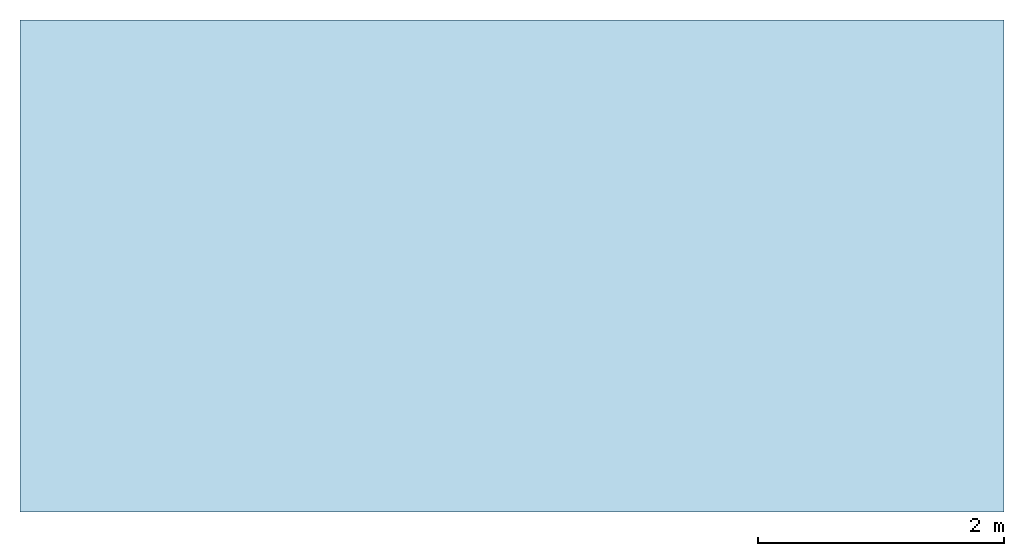
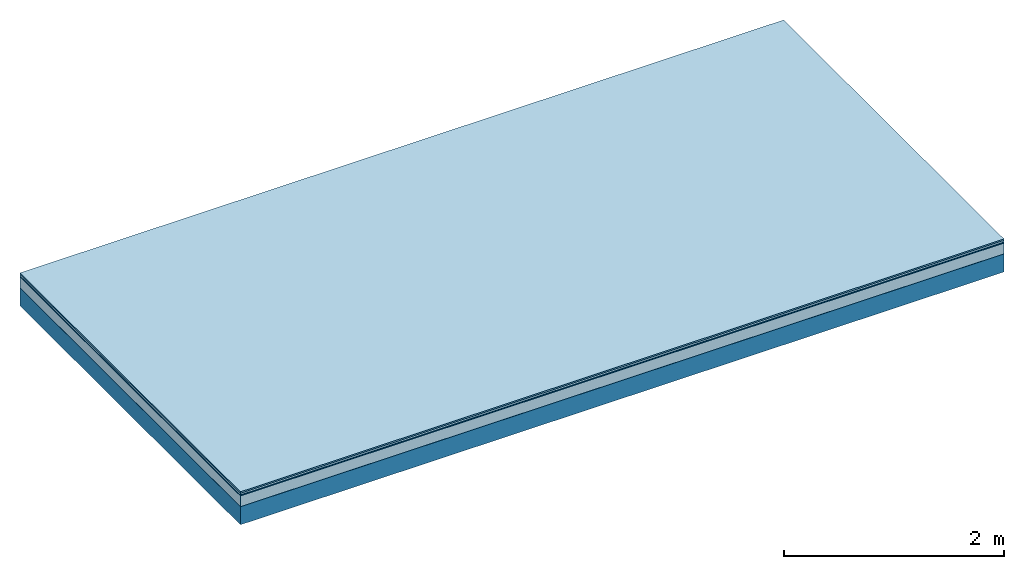
# One storey: 5 plates, 1 member, 1 element without a shape of its own.
"""IFC4 building model written with IfcOpenShell, lengths in metres."""

from ifc_helpers import new_model, si_unit, derived_unit, direction, frame, frame_2d, origin, origin_with_axes, place, context, project, spatial, rectangle, extrude, material, layer, layer_set, type_object, element, aggregate, save


model = new_model("IFC4")

# Units and contexts
plan_context = context("Plan", 3, precision=1e-05, world=origin(), true_north=direction((0.0, 1.0)))
model_context = context("Model", 3, precision=1e-05, world=origin(), true_north=direction((0.0, 1.0)))
ifc_project = project(units=[si_unit("LENGTHUNIT", "METRE"), derived_unit("SOUNDPRESSUREUNIT", [(si_unit("PRESSUREUNIT", "PASCAL", prefix="MICRO"), 0)]), si_unit("ENERGYUNIT", "JOULE", prefix="MEGA"), si_unit("MASSUNIT", "GRAM", prefix="KILO"), derived_unit("THERMALTRANSMITTANCEUNIT", [(si_unit("POWERUNIT", "WATT"), 1), (si_unit("AREAUNIT", "SQUARE_METRE"), -1), (si_unit("THERMODYNAMICTEMPERATUREUNIT", "KELVIN"), -1)]), derived_unit("AREADENSITYUNIT", [(si_unit("MASSUNIT", "GRAM", prefix="KILO"), 1), (si_unit("AREAUNIT", "SQUARE_METRE"), -1)]), derived_unit("USERDEFINED", [(si_unit("ENERGYUNIT", "JOULE", prefix="MEGA"), 1), (si_unit("AREAUNIT", "SQUARE_METRE"), -1)])], contexts=[plan_context, model_context])

# Site, building, storey
site = spatial("IfcSite", under=ifc_project)
building_placement = place(None, origin())
building = spatial("IfcBuilding", under=site, at=building_placement)
storey_placement = place(building_placement, origin())
storey = spatial("IfcBuildingStorey", under=building, at=storey_placement)

# Slab, member, plates
ifc_material_1 = material(Category="11.013")
ifc_layer_1 = layer(ifc_material_1, 0.015, Name="Flooring")
ifc_material_2 = material(Category="03.007")
ifc_layer_2 = layer(ifc_material_2, 0.02, Name="On-material")
ifc_material_3 = material(Name="Wood fiber generic product", Category="10.009")
ifc_layer_3 = layer(ifc_material_3, 0.01, Name="Impact sound insulation")
ifc_material_4 = material(Category="03.011")
ifc_layer_4 = layer(ifc_material_4, 0.12, Name="on Supporting structure")
ifc_material_5 = material(Name="protection", Category="09.007")
ifc_layer_5 = layer(ifc_material_5, 0.0005, Name="Sub-floor")
ifc_material_6 = material(Name="no composite action")
ifc_layer_6 = layer(ifc_material_6, 0.0, Name="Bond")
ifc_layer_7 = layer(None, 0.2, Name="Supporting structure")
ifc_layer_set = layer_set([ifc_layer_1, ifc_layer_2, ifc_layer_3, ifc_layer_4, ifc_layer_5, ifc_layer_6, ifc_layer_7])
slab_type = type_object("IfcSlabType", Name="A2055", PredefinedType="NOTDEFINED", material=ifc_layer_set)
slab_placement = place(None, frame((0.0, 0.0, 0.0), z_axis=(0.0, 0.0, -1.0), x_axis=(1.0, 0.0, 0.0)))
slab = element("IfcSlab", 1, at=slab_placement, inside=storey, type_object=slab_type, material=ifc_layer_set, Name="Slab #1")
ifc_material_7 = material(Name="Solid timber panel")
member_placement = place(slab_placement, origin())
member = element("IfcMember", 2, at=member_placement, material=ifc_material_7, Name="Supporting structure", context=plan_context, shape_type="SweptSolid", body=[
    extrude(rectangle(XDim=1.0, YDim=0.2, at=frame_2d((0.5, 0.1), x_axis=(1.0, 0.0))), frame((0.0, 4.0, 0.1655), z_axis=(0.0, -1.0, 0.0), x_axis=(1.0, 0.0, 0.0)), (0.0, 0.0, 1.0), 4.0),
    extrude(rectangle(XDim=1.0, YDim=0.2, at=frame_2d((0.5, 0.1), x_axis=(1.0, 0.0))), frame((1.0, 4.0, 0.1655), z_axis=(0.0, -1.0, 0.0), x_axis=(1.0, 0.0, 0.0)), (0.0, 0.0, 1.0), 4.0),
    extrude(rectangle(XDim=1.0, YDim=0.2, at=frame_2d((0.5, 0.1), x_axis=(1.0, 0.0))), frame((2.0, 4.0, 0.1655), z_axis=(0.0, -1.0, 0.0), x_axis=(1.0, 0.0, 0.0)), (0.0, 0.0, 1.0), 4.0),
    extrude(rectangle(XDim=1.0, YDim=0.2, at=frame_2d((0.5, 0.1), x_axis=(1.0, 0.0))), frame((3.0, 4.0, 0.1655), z_axis=(0.0, -1.0, 0.0), x_axis=(1.0, 0.0, 0.0)), (0.0, 0.0, 1.0), 4.0),
    extrude(rectangle(XDim=1.0, YDim=0.2, at=frame_2d((0.5, 0.1), x_axis=(1.0, 0.0))), frame((4.0, 4.0, 0.1655), z_axis=(0.0, -1.0, 0.0), x_axis=(1.0, 0.0, 0.0)), (0.0, 0.0, 1.0), 4.0),
    extrude(rectangle(XDim=1.0, YDim=0.2, at=frame_2d((0.5, 0.1), x_axis=(1.0, 0.0))), frame((5.0, 4.0, 0.1655), z_axis=(0.0, -1.0, 0.0), x_axis=(1.0, 0.0, 0.0)), (0.0, 0.0, 1.0), 4.0),
    extrude(rectangle(XDim=1.0, YDim=0.2, at=frame_2d((0.5, 0.1), x_axis=(1.0, 0.0))), frame((6.0, 4.0, 0.1655), z_axis=(0.0, -1.0, 0.0), x_axis=(1.0, 0.0, 0.0)), (0.0, 0.0, 1.0), 4.0),
    extrude(rectangle(XDim=1.0, YDim=0.2, at=frame_2d((0.5, 0.1), x_axis=(1.0, 0.0))), frame((7.0, 4.0, 0.1655), z_axis=(0.0, -1.0, 0.0), x_axis=(1.0, 0.0, 0.0)), (0.0, 0.0, 1.0), 4.0),
])
plate_1_placement = place(slab_placement, origin())
plate_1 = element("IfcPlate", 3, at=plate_1_placement, material=ifc_material_1, Name="Flooring", context=plan_context, shape_type="SweptSolid", body=[
    extrude(rectangle(XDim=8.0, YDim=4.0, at=frame_2d((4.0, 2.0), x_axis=(1.0, 0.0))), origin_with_axes(), (0.0, 0.0, 1.0), 0.015),
])
plate_2_placement = place(slab_placement, origin())
plate_2 = element("IfcPlate", 4, at=plate_2_placement, material=ifc_material_2, Name="On-material", context=plan_context, shape_type="SweptSolid", body=[
    extrude(rectangle(XDim=8.0, YDim=4.0, at=frame_2d((4.0, 2.0), x_axis=(1.0, 0.0))), frame((0.0, 0.0, 0.015), z_axis=(0.0, 0.0, 1.0), x_axis=(1.0, 0.0, 0.0)), (0.0, 0.0, 1.0), 0.02),
])
plate_3_placement = place(slab_placement, origin())
plate_3 = element("IfcPlate", 5, at=plate_3_placement, material=ifc_material_3, Name="Impact sound insulation", context=plan_context, shape_type="SweptSolid", body=[
    extrude(rectangle(XDim=8.0, YDim=4.0, at=frame_2d((4.0, 2.0), x_axis=(1.0, 0.0))), frame((0.0, 0.0, 0.035), z_axis=(0.0, 0.0, 1.0), x_axis=(1.0, 0.0, 0.0)), (0.0, 0.0, 1.0), 0.01),
])
plate_4_placement = place(slab_placement, origin())
plate_4 = element("IfcPlate", 6, at=plate_4_placement, material=ifc_material_4, Name="on Supporting structure", context=plan_context, shape_type="SweptSolid", body=[
    extrude(rectangle(XDim=8.0, YDim=4.0, at=frame_2d((4.0, 2.0), x_axis=(1.0, 0.0))), frame((0.0, 0.0, 0.045), z_axis=(0.0, 0.0, 1.0), x_axis=(1.0, 0.0, 0.0)), (0.0, 0.0, 1.0), 0.12),
])
plate_5_placement = place(slab_placement, origin())
plate_5 = element("IfcPlate", 7, at=plate_5_placement, material=ifc_material_5, Name="Sub-floor", context=plan_context, shape_type="SweptSolid", body=[
    extrude(rectangle(XDim=8.0, YDim=4.0, at=frame_2d((4.0, 2.0), x_axis=(1.0, 0.0))), frame((0.0, 0.0, 0.165), z_axis=(0.0, 0.0, 1.0), x_axis=(1.0, 0.0, 0.0)), (0.0, 0.0, 1.0), 0.0005),
])
aggregate(slab, [plate_1, plate_2, plate_3, plate_4, plate_5, member])

save(model, "model.ifc")
